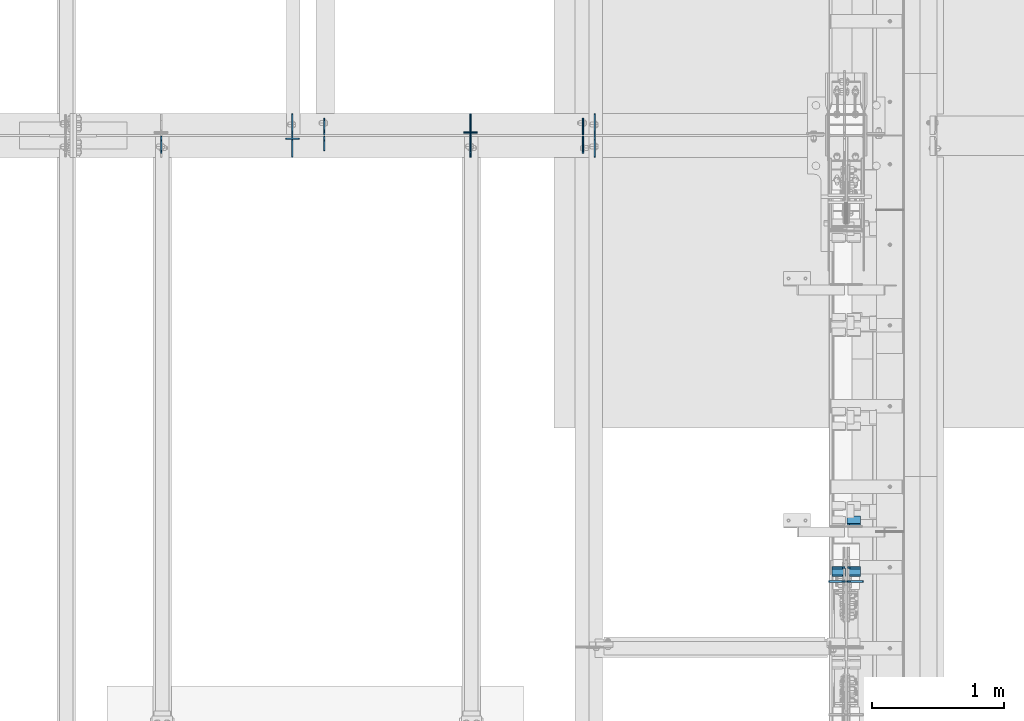
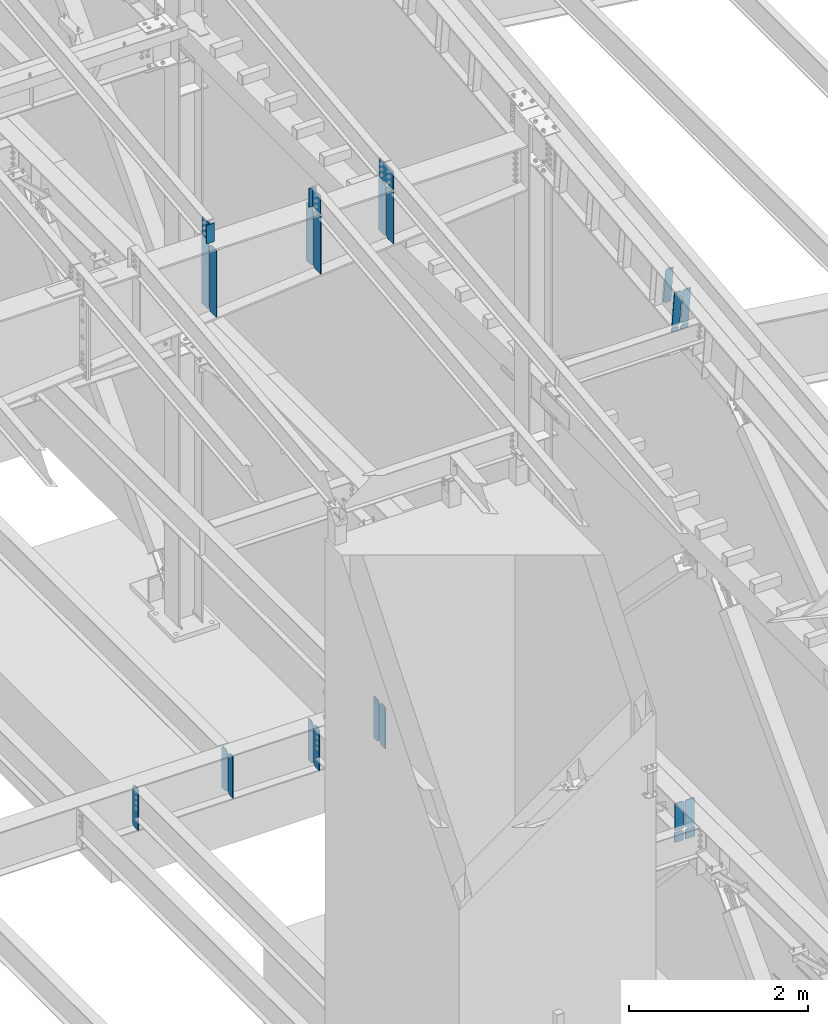
# One storey, part 1032 of 1179: 27 plates, 4 elements without a shape of their own.
"""IFC2X3 building model written with IfcOpenShell, lengths in millimetres."""

from ifc_helpers import new_model, si_unit, frame, origin_with_axes, place, context, subcontext, project, spatial, faceted_brep, material, type_object, element, aggregate, save


model = new_model("IFC2X3")

# Units and contexts
model_context = context("Model", 3, precision=1e-05, world=origin_with_axes())
body_context = subcontext(model_context, "Body", "Model", "MODEL_VIEW")
ifc_project = project(units=[si_unit("LENGTHUNIT", "METRE", prefix="MILLI"), si_unit("AREAUNIT", "SQUARE_METRE"), si_unit("VOLUMEUNIT", "CUBIC_METRE"), si_unit("MASSUNIT", "GRAM", prefix="KILO"), si_unit("TIMEUNIT", "SECOND"), si_unit("PLANEANGLEUNIT", "RADIAN"), si_unit("SOLIDANGLEUNIT", "STERADIAN"), si_unit("THERMODYNAMICTEMPERATUREUNIT", "DEGREE_CELSIUS"), si_unit("LUMINOUSINTENSITYUNIT", "LUMEN")], contexts=[model_context])

# Site, building, storey
site_placement = place(None, origin_with_axes())
site = spatial("IfcSite", under=ifc_project, at=site_placement, CompositionType="ELEMENT")
building_placement = place(site_placement, origin_with_axes())
building = spatial("IfcBuilding", under=site, at=building_placement, Name="Undefined", CompositionType="ELEMENT")
storey_placement = place(building_placement, origin_with_axes())
storey = spatial("IfcBuildingStorey", under=building, at=storey_placement, Name="Undefined", CompositionType="ELEMENT", Elevation=0.0)

# Assembly, plates
assembly_1_placement = place(storey_placement, origin_with_axes())
assembly_1 = element("IfcElementAssembly", 1, at=assembly_1_placement, inside=storey, Name="BEAM", AssemblyPlace="NOTDEFINED", PredefinedType="RIGID_FRAME")
ifc_material_1 = material(Name="STEEL/A36")
plate_type_1 = type_object("IfcPlateType", PredefinedType="NOTDEFINED")
plate_1_placement = place(assembly_1_placement, frame((22318.661882941, 19222.24375, 3514.725), z_axis=(0.0, 0.0, 1.0), x_axis=(0.0, -1.0, 0.0)))
plate_1 = element("IfcPlate", 2, at=plate_1_placement, type_object=plate_type_1, material=ifc_material_1, Name="PLATE", context=body_context, shape_type="Brep", body=[
    faceted_brep([(108.743750000001, -4.76250000000073, 571.5), (108.743750000001, -4.76250000000073, 568.324999809266), (108.743750000001, 4.76250000000073, 568.324999809266), (108.743750000001, 4.76250000000073, 571.5), (109.710479922593, -4.76250000000073, 563.46492029122), (109.710479922593, 4.76250000000073, 563.46492029122), (112.463493823067, -4.76250000000073, 559.344743823066), (112.463493823067, 4.76250000000073, 559.344743823066), (116.58367029122, -4.76250000000073, 556.591729922588), (116.58367029122, 4.76250000000073, 556.591729922588), (121.443749809267, -4.76250000000073, 555.625), (121.443749809267, 4.76250000000073, 555.625), (127.000004116075, -4.76250000000073, 555.625), (127.000004116075, 4.76250000000073, 555.625), (0.0, -4.76250000000073, 536.575000762939), (34.9249992370605, -4.76250000000073, 571.5), (34.9249992370605, 4.76250000000073, 571.5), (0.0, 4.76250000000073, 536.575000762939), (0.0, -4.76250000000073, 34.9249999999993), (0.0, 4.76250000000073, 34.9249999999993), (34.9249992370715, -4.76249999996799, 0.0), (34.9249992370678, 4.76250000003347, 0.0), (127.0, -4.76250000000073, 0.0), (127.0, 4.76250000000073, 0.0)], [[[0, 1, 2, 3]], [[4, 5, 2, 1]], [[6, 7, 5, 4]], [[8, 9, 7, 6]], [[10, 11, 9, 8]], [[12, 13, 11, 10]], [[14, 15, 16, 17]], [[18, 14, 17, 19]], [[20, 18, 19, 21]], [[22, 20, 21, 23]], [[8, 6, 4, 1, 0, 15, 14, 18, 20, 22, 12, 10]], [[16, 15, 0, 3]], [[23, 21, 19, 17, 16, 3, 2, 5, 7, 9, 11, 13]], [[22, 23, 13, 12]]]),
])
plate_2_placement = place(assembly_1_placement, frame((22318.6620000839, 19233.35625, 3514.725), z_axis=(0.0, 0.0, 1.0), x_axis=(0.0, 1.0, 0.0)))
plate_2 = element("IfcPlate", 3, at=plate_2_placement, type_object=plate_type_1, material=ifc_material_1, Name="PLATE", context=body_context, shape_type="Brep", body=[
    faceted_brep([(108.743750000001, -4.76250000000073, 571.5), (108.743750000001, -4.76250000000073, 568.324999809266), (108.743750000001, 4.76250000000073, 568.324999809266), (108.743750000001, 4.76250000000073, 571.5), (109.710479922593, -4.76250000000073, 563.46492029122), (109.710479922593, 4.76250000000073, 563.46492029122), (112.463493823067, -4.76250000000073, 559.344743823066), (112.463493823067, 4.76250000000073, 559.344743823066), (116.58367029122, -4.76250000000073, 556.591729922588), (116.58367029122, 4.76250000000073, 556.591729922588), (121.443749809267, -4.76250000000073, 555.625), (121.443749809267, 4.76250000000073, 555.625), (127.000004116075, -4.76250000000073, 555.625), (127.000004116075, 4.76250000000073, 555.625), (0.0, -4.76250000000073, 536.575000762939), (34.9249992370605, -4.76250000000073, 571.5), (34.9249992370605, 4.76250000000073, 571.5), (0.0, 4.76250000000073, 536.575000762939), (0.0, -4.76250000000073, 34.9249999999993), (0.0, 4.76250000000073, 34.9249999999993), (34.9249992370715, -4.76249999996799, 0.0), (34.9249992370678, 4.76250000003347, 0.0), (127.0, -4.76250000000073, 0.0), (127.0, 4.76250000000073, 0.0)], [[[0, 1, 2, 3]], [[4, 5, 2, 1]], [[6, 7, 5, 4]], [[8, 9, 7, 6]], [[10, 11, 9, 8]], [[12, 13, 11, 10]], [[14, 15, 16, 17]], [[18, 14, 17, 19]], [[20, 18, 19, 21]], [[22, 20, 21, 23]], [[8, 6, 4, 1, 0, 15, 14, 18, 20, 22, 12, 10]], [[16, 15, 0, 3]], [[23, 21, 19, 17, 16, 3, 2, 5, 7, 9, 11, 13]], [[22, 23, 13, 12]]]),
])
plate_3_placement = place(assembly_1_placement, frame((20362.8620000839, 19233.35625, 3514.725), z_axis=(0.0, 0.0, 1.0), x_axis=(0.0, 1.0, 0.0)))
plate_3 = element("IfcPlate", 4, at=plate_3_placement, type_object=plate_type_1, material=ifc_material_1, Name="PLATE", context=body_context, shape_type="Brep", body=[
    faceted_brep([(108.743602752693, -4.76250000000073, 571.5), (108.743602752693, -4.76188288369667, 568.324999809298), (108.743602752693, 4.76250000000073, 568.324999809298), (108.743602752693, 4.76250000000073, 571.5), (109.71033267528, -4.76188288369667, 563.464920291253), (109.71033267528, 4.76250000000073, 563.464920291253), (112.463346575758, -4.76188288369667, 559.344743823099), (112.463346575758, 4.76250000000073, 559.344743823099), (116.583523043912, -4.76188288369667, 556.591729922621), (116.583523043912, 4.76250000000073, 556.591729922621), (121.443602561958, -4.76188288369667, 555.625000000033), (121.443602561958, 4.76250000000073, 555.625000000033), (127.000007629402, -4.76188288369667, 555.625000000033), (127.000004116075, 4.76250000000073, 555.625), (0.0, -4.76250000000073, 536.575000762939), (34.9249992370605, -4.76250000000073, 571.5), (34.9249992370605, 4.76250000000073, 571.5), (0.0, 4.76250000000073, 536.575000762939), (0.0, -4.76250000000073, 34.9249999999993), (0.0, 4.76250000000073, 34.9249999999993), (34.9249992370715, -4.76249999996799, 0.0), (34.9249992370678, 4.76250000003347, 0.0), (127.0, -4.76250000000073, 0.0), (127.0, 4.76250000000073, 0.0)], [[[0, 1, 2, 3]], [[4, 5, 2, 1]], [[6, 7, 5, 4]], [[8, 9, 7, 6]], [[10, 11, 9, 8]], [[12, 13, 11, 10]], [[14, 15, 16, 17]], [[18, 14, 17, 19]], [[20, 18, 19, 21]], [[22, 20, 21, 23]], [[8, 6, 4, 1, 0, 15, 14, 18, 20, 22, 12, 10]], [[16, 15, 0, 3]], [[23, 21, 19, 17, 16, 3, 2, 5, 7, 9, 11, 13]], [[22, 23, 13, 12]]]),
])
plate_4_placement = place(assembly_1_placement, frame((21467.7620000839, 19222.24375, 3514.725), z_axis=(0.0, 0.0, 1.0), x_axis=(0.0, -1.0, 0.0)))
plate_4 = element("IfcPlate", 5, at=plate_4_placement, type_object=plate_type_1, material=ifc_material_1, Name="PLATE", context=body_context, shape_type="Brep", body=[
    faceted_brep([(108.743602752693, -4.76250000000073, 571.5), (108.743602752693, -4.76188288369667, 568.324999809298), (108.743602752693, 4.76250000000073, 568.324999809298), (108.743602752693, 4.76250000000073, 571.5), (109.71033267528, -4.76188288369667, 563.464920291253), (109.71033267528, 4.76250000000073, 563.464920291253), (112.463346575758, -4.76188288369667, 559.344743823099), (112.463346575758, 4.76250000000073, 559.344743823099), (116.583523043912, -4.76188288369667, 556.591729922621), (116.583523043912, 4.76250000000073, 556.591729922621), (121.443602561958, -4.76188288369667, 555.625000000033), (121.443602561958, 4.76250000000073, 555.625000000033), (127.000007629402, -4.76188288369667, 555.625000000033), (127.000004116075, 4.76250000000073, 555.625), (0.0, -4.76250000000073, 536.575000762939), (34.9249992370605, -4.76250000000073, 571.5), (34.9249992370605, 4.76250000000073, 571.5), (0.0, 4.76250000000073, 536.575000762939), (0.0, -4.76250000000073, 34.9249999999993), (0.0, 4.76250000000073, 34.9249999999993), (34.9249992370715, -4.76249999996799, 0.0), (34.9249992370678, 4.76250000003347, 0.0), (127.0, -4.76250000000073, 0.0), (127.0, 4.76250000000073, 0.0)], [[[0, 1, 2, 3]], [[4, 5, 2, 1]], [[6, 7, 5, 4]], [[8, 9, 7, 6]], [[10, 11, 9, 8]], [[12, 13, 11, 10]], [[14, 15, 16, 17]], [[18, 14, 17, 19]], [[20, 18, 19, 21]], [[22, 20, 21, 23]], [[8, 6, 4, 1, 0, 15, 14, 18, 20, 22, 12, 10]], [[16, 15, 0, 3]], [[23, 21, 19, 17, 16, 3, 2, 5, 7, 9, 11, 13]], [[22, 23, 13, 12]]]),
])
plate_5_placement = place(assembly_1_placement, frame((19130.9620000839, 19222.24375, 3514.725), z_axis=(0.0, 0.0, 1.0), x_axis=(0.0, -1.0, 0.0)))
plate_5 = element("IfcPlate", 6, at=plate_5_placement, type_object=plate_type_1, material=ifc_material_1, Name="PLATE", context=body_context, shape_type="Brep", body=[
    faceted_brep([(108.743602752693, -4.76250000000073, 571.5), (108.743602752693, -4.76188288369667, 568.324999809298), (108.743602752693, 4.76250000000073, 568.324999809298), (108.743602752693, 4.76250000000073, 571.5), (109.71033267528, -4.76188288369667, 563.464920291253), (109.71033267528, 4.76250000000073, 563.464920291253), (112.463346575758, -4.76188288369667, 559.344743823099), (112.463346575758, 4.76250000000073, 559.344743823099), (116.583523043912, -4.76188288369667, 556.591729922621), (116.583523043912, 4.76250000000073, 556.591729922621), (121.443602561958, -4.76188288369667, 555.625000000033), (121.443602561958, 4.76250000000073, 555.625000000033), (127.000007629402, -4.76188288369667, 555.625000000033), (127.000004116075, 4.76250000000073, 555.625), (0.0, -4.76250000000073, 536.575000762939), (34.9249992370605, -4.76250000000073, 571.5), (34.9249992370605, 4.76250000000073, 571.5), (0.0, 4.76250000000073, 536.575000762939), (0.0, -4.76250000000073, 34.9249999999993), (0.0, 4.76250000000073, 34.9249999999993), (34.9249992370715, -4.76249999996799, 0.0), (34.9249992370678, 4.76250000003347, 0.0), (127.0, -4.76250000000073, 0.0), (127.0, 4.76250000000073, 0.0)], [[[0, 1, 2, 3]], [[4, 5, 2, 1]], [[6, 7, 5, 4]], [[8, 9, 7, 6]], [[10, 11, 9, 8]], [[12, 13, 11, 10]], [[14, 15, 16, 17]], [[18, 14, 17, 19]], [[20, 18, 19, 21]], [[22, 20, 21, 23]], [[8, 6, 4, 1, 0, 15, 14, 18, 20, 22, 12, 10]], [[16, 15, 0, 3]], [[23, 21, 19, 17, 16, 3, 2, 5, 7, 9, 11, 13]], [[22, 23, 13, 12]]]),
])

assembly_2_placement = place(storey_placement, origin_with_axes())
assembly_2 = element("IfcElementAssembly", 7, at=assembly_2_placement, inside=storey, Name="RAFTER BEAM", AssemblyPlace="NOTDEFINED", PredefinedType="RIGID_FRAME")
plate_type_2 = type_object("IfcPlateType", PredefinedType="NOTDEFINED")
plate_6_placement = place(assembly_2_placement, frame((20121.5625009335, 19392.8999999624, 11103.7687496185), z_axis=(0.0, 0.0, -1.0), x_axis=(0.0, -1.0, 0.0)))
plate_6 = element("IfcPlate", 8, at=plate_6_placement, type_object=plate_type_2, material=ifc_material_1, Name="PLATE", context=body_context, shape_type="Brep", body=[
    faceted_brep([(0.0, -4.76249999999709, 0.0), (-2.08691562875174e-06, -4.76250000000073, 913.722326068595), (-2.08691562875174e-06, 4.76250000000073, 913.722326068595), (0.0, 4.76249999999709, 0.0), (131.762498294553, -4.76250000000073, 913.722326388206), (131.762498294553, 4.76250000000073, 913.722326388206), (157.162497971098, -4.76250000000073, 888.322326831285), (157.162497971098, 4.76250000000073, 888.322326831285), (157.162499942613, -4.76250000000073, 25.3999996182793), (157.162499942613, 4.76250000000073, 25.3999996182793), (131.762500381465, -4.76250000000073, -2.09183781407773e-10), (131.762500381465, 4.76250000000073, -2.09183781407773e-10)], [[[0, 1, 2, 3]], [[1, 4, 5, 2]], [[4, 6, 7, 5]], [[6, 8, 9, 7]], [[8, 10, 11, 9]], [[10, 0, 3, 11]], [[5, 7, 9, 11, 3, 2]], [[10, 8, 6, 4, 1, 0]]]),
])
plate_7_placement = place(assembly_2_placement, frame((21467.7625, 19392.8999999624, 11103.7687496185), z_axis=(0.0, 0.0, -1.0), x_axis=(0.0, -1.0, 0.0)))
plate_7 = element("IfcPlate", 9, at=plate_7_placement, type_object=plate_type_2, material=ifc_material_1, Name="PLATE", context=body_context, shape_type="Brep", body=[
    faceted_brep([(0.0, -4.76249999999709, 0.0), (-1.85116005013697e-06, -4.76250000000073, 795.843735329721), (-1.85116005013697e-06, 4.76250000000073, 795.843735329721), (0.0, 4.76249999999709, 0.0), (131.762498530312, -4.76250000000073, 795.843735649332), (131.762498530312, 4.76250000000073, 795.843735649332), (157.162498207919, -4.76250000000073, 770.443736092411), (157.162498207919, 4.76250000000073, 770.443736092411), (157.162499942613, -4.76250000000073, 25.3999996182793), (157.162499942613, 4.76250000000073, 25.3999996182793), (131.762500381465, -4.76250000000073, -2.09183781407773e-10), (131.762500381465, 4.76250000000073, -2.09183781407773e-10)], [[[0, 1, 2, 3]], [[1, 4, 5, 2]], [[4, 6, 7, 5]], [[6, 8, 9, 7]], [[8, 10, 11, 9]], [[10, 0, 3, 11]], [[5, 7, 9, 11, 3, 2]], [[10, 8, 6, 4, 1, 0]]]),
])
plate_8_placement = place(assembly_2_placement, frame((22407.5625, 19392.8999999624, 11103.7687496185), z_axis=(0.0, 0.0, -1.0), x_axis=(0.0, -1.0, 0.0)))
plate_8 = element("IfcPlate", 10, at=plate_8_placement, type_object=plate_type_2, material=ifc_material_1, Name="PLATE", context=body_context, shape_type="Brep", body=[
    faceted_brep([(0.0, -4.76249999999709, 0.0), (-1.68650149134919e-06, -4.76250000000073, 713.502596248929), (-1.68650149134919e-06, 4.76250000000073, 713.502596248929), (0.0, 4.76249999999709, 0.0), (131.762498694967, -4.76250000000073, 713.50259656854), (131.762498694967, 4.76250000000073, 713.50259656854), (157.162498373538, -4.76250000000073, 688.102597011619), (157.162498373538, 4.76250000000073, 688.102597011619), (157.162499942613, -4.76250000000073, 25.3999996182793), (157.162499942613, 4.76250000000073, 25.3999996182793), (131.762500381465, -4.76250000000073, -2.09183781407773e-10), (131.762500381465, 4.76250000000073, -2.09183781407773e-10)], [[[0, 1, 2, 3]], [[1, 4, 5, 2]], [[4, 6, 7, 5]], [[6, 8, 9, 7]], [[8, 10, 11, 9]], [[10, 0, 3, 11]], [[5, 7, 9, 11, 3, 2]], [[10, 8, 6, 4, 1, 0]]]),
])
plate_9_placement = place(assembly_2_placement, frame((20121.5625009335, 19062.6999999987, 11103.7687496185), z_axis=(0.0, 0.0, -1.0), x_axis=(0.0, 1.0, 0.0)))
plate_9 = element("IfcPlate", 11, at=plate_9_placement, type_object=plate_type_2, material=ifc_material_1, Name="PLATE", context=body_context, shape_type="Brep", body=[
    faceted_brep([(0.0, -4.76249999999709, 0.0), (-2.08691562875174e-06, -4.76250000000073, 913.722326068595), (-2.08691562875174e-06, 4.76250000000073, 913.722326068595), (0.0, 4.76249999999709, 0.0), (131.762498294553, -4.76250000000073, 913.722326388206), (131.762498294553, 4.76250000000073, 913.722326388206), (157.162497971098, -4.76250000000073, 888.322326831285), (157.162497971098, 4.76250000000073, 888.322326831285), (157.162499942613, -4.76250000000073, 25.3999996182793), (157.162499942613, 4.76250000000073, 25.3999996182793), (131.762500381465, -4.76250000000073, -2.09183781407773e-10), (131.762500381465, 4.76250000000073, -2.09183781407773e-10)], [[[0, 1, 2, 3]], [[1, 4, 5, 2]], [[4, 6, 7, 5]], [[6, 8, 9, 7]], [[8, 10, 11, 9]], [[10, 0, 3, 11]], [[5, 7, 9, 11, 3, 2]], [[10, 8, 6, 4, 1, 0]]]),
])
plate_10_placement = place(assembly_2_placement, frame((21467.7625, 19062.6999999987, 11103.7687496185), z_axis=(0.0, 0.0, -1.0), x_axis=(0.0, 1.0, 0.0)))
plate_10 = element("IfcPlate", 12, at=plate_10_placement, type_object=plate_type_2, material=ifc_material_1, Name="PLATE", context=body_context, shape_type="Brep", body=[
    faceted_brep([(0.0, -4.76249999999709, 0.0), (-1.85116005013697e-06, -4.76250000000073, 795.843735329721), (-1.85116005013697e-06, 4.76250000000073, 795.843735329721), (0.0, 4.76249999999709, 0.0), (131.762498530312, -4.76250000000073, 795.843735649332), (131.762498530312, 4.76250000000073, 795.843735649332), (157.162498207919, -4.76250000000073, 770.443736092411), (157.162498207919, 4.76250000000073, 770.443736092411), (157.162499942613, -4.76250000000073, 25.3999996182793), (157.162499942613, 4.76250000000073, 25.3999996182793), (131.762500381465, -4.76250000000073, -2.09183781407773e-10), (131.762500381465, 4.76250000000073, -2.09183781407773e-10)], [[[0, 1, 2, 3]], [[1, 4, 5, 2]], [[4, 6, 7, 5]], [[6, 8, 9, 7]], [[8, 10, 11, 9]], [[10, 0, 3, 11]], [[5, 7, 9, 11, 3, 2]], [[10, 8, 6, 4, 1, 0]]]),
])
plate_11_placement = place(assembly_2_placement, frame((22407.5625, 19062.6999999987, 11103.7687496185), z_axis=(0.0, 0.0, -1.0), x_axis=(0.0, 1.0, 0.0)))
plate_11 = element("IfcPlate", 13, at=plate_11_placement, type_object=plate_type_2, material=ifc_material_1, Name="PLATE", context=body_context, shape_type="Brep", body=[
    faceted_brep([(0.0, -4.76249999999709, 0.0), (-1.68650149134919e-06, -4.76250000000073, 713.502596248929), (-1.68650149134919e-06, 4.76250000000073, 713.502596248929), (0.0, 4.76249999999709, 0.0), (131.762498694967, -4.76250000000073, 713.50259656854), (131.762498694967, 4.76250000000073, 713.50259656854), (157.162498373538, -4.76250000000073, 688.102597011619), (157.162498373538, 4.76250000000073, 688.102597011619), (157.162499942613, -4.76250000000073, 25.3999996182793), (157.162499942613, 4.76250000000073, 25.3999996182793), (131.762500381465, -4.76250000000073, -2.09183781407773e-10), (131.762500381465, 4.76250000000073, -2.09183781407773e-10)], [[[0, 1, 2, 3]], [[1, 4, 5, 2]], [[4, 6, 7, 5]], [[6, 8, 9, 7]], [[8, 10, 11, 9]], [[10, 0, 3, 11]], [[5, 7, 9, 11, 3, 2]], [[10, 8, 6, 4, 1, 0]]]),
])

assembly_3_placement = place(storey_placement, origin_with_axes())
assembly_3 = element("IfcElementAssembly", 14, at=assembly_3_placement, inside=storey, Name="BEAM", AssemblyPlace="NOTDEFINED", PredefinedType="RIGID_FRAME")
ifc_material_2 = material(Name="STEEL/A572-GR.50")
plate_type_3 = type_object("IfcPlateType", PredefinedType="NOTDEFINED")
plate_12_placement = place(assembly_3_placement, frame((24414.1625, 15956.4822255243, 10522.7324669525), z_axis=(0.0, -0.112284087038017, 0.993676146336441), x_axis=(-1.0, 0.0, 0.0)))
plate_12 = element("IfcPlate", 15, at=plate_12_placement, type_object=plate_type_3, material=ifc_material_2, Name="PLATE", context=body_context, shape_type="Brep", body=[
    faceted_brep([(0.0, -6.34999999999854, 0.0), (0.0, -6.35000000019863, 498.474999998592), (0.0, 6.34999999979118, 498.474999998596), (0.0, 6.34999999999854, 0.0), (80.1687507629395, -6.35000000020227, 498.474999998592), (80.1687507629395, 6.34999999978754, 498.474999998596), (99.21875, -6.350000000195, 479.425000761543), (99.21875, 6.34999999980209, 479.425000761548), (99.21875, -6.35000000000946, 19.0499992370478), (99.21875, 6.34999999998399, 19.0499992370533), (80.1687507629395, -6.35000000000218, 0.0), (80.1687507629395, 6.34999999999491, 3.63797880709171e-12)], [[[0, 1, 2, 3]], [[1, 4, 5, 2]], [[4, 6, 7, 5]], [[6, 8, 9, 7]], [[8, 10, 11, 9]], [[10, 0, 3, 11]], [[5, 7, 9, 11, 3, 2]], [[10, 8, 6, 4, 1, 0]]]),
])
plate_13_placement = place(assembly_3_placement, frame((24300.65625, 15956.4822255243, 10522.7324669525), z_axis=(0.0, -0.112284087038017, 0.993676146336441), x_axis=(-1.0, 0.0, 0.0)))
plate_13 = element("IfcPlate", 16, at=plate_13_placement, type_object=plate_type_3, material=ifc_material_2, Name="PLATE", context=body_context, shape_type="Brep", body=[
    faceted_brep([(0.0, -6.35000000000036, 19.0499999999993), (0.0, -6.350000000195, 479.425000761541), (0.0, 6.34999999980209, 479.425000761548), (0.0, 6.35000000000036, 19.0499999999993), (19.0499992370605, -6.35000000019863, 498.474999998592), (19.0499992370605, 6.34999999979118, 498.474999998596), (99.21875, -6.35000000020227, 498.474999998592), (99.21875, 6.34999999978754, 498.474999998596), (99.21875, -6.35000000000218, 0.0), (99.21875, 6.34999999999491, 3.63797880709171e-12), (19.0500000000002, -6.35000000000036, 0.0), (19.0500000000002, 6.35000000000036, 0.0)], [[[0, 1, 2, 3]], [[1, 4, 5, 2]], [[4, 6, 7, 5]], [[6, 8, 9, 7]], [[8, 10, 11, 9]], [[3, 11, 10, 0]], [[5, 7, 9, 11, 3, 2]], [[10, 8, 6, 4, 1, 0]]]),
])

assembly_4_placement = place(storey_placement, origin_with_axes())
assembly_4 = element("IfcElementAssembly", 17, at=assembly_4_placement, inside=storey, Name="BEAM", AssemblyPlace="NOTDEFINED", PredefinedType="RIGID_FRAME")
plate_type_4 = type_object("IfcPlateType", PredefinedType="NOTDEFINED")
plate_14_placement = place(assembly_4_placement, frame((24434.00625, 15857.8351561904, 3703.6375), z_axis=(0.0, 0.0, 1.0), x_axis=(-1.0, 0.0, 0.0)))
plate_14 = element("IfcPlate", 18, at=plate_14_placement, type_object=plate_type_4, material=ifc_material_2, Name="PLATE", context=body_context, shape_type="Brep", body=[
    faceted_brep([(0.0, -6.34999999999854, 0.0), (0.0, -6.35000000000036, 377.825012207031), (0.0, 6.35000000000036, 377.825012207031), (0.0, 6.34999999999854, 0.0), (98.4250011444092, -6.35000000000036, 377.825012207031), (98.4250011444092, 6.35000000000036, 377.825012207031), (120.650001525879, -6.35000000000036, 355.600011825562), (120.650001525879, 6.35000000000036, 355.600011825562), (120.650001525879, -6.35000000000036, 22.2250003814697), (120.650001525879, 6.35000000000036, 22.2250003814697), (98.4250011444092, -6.35000000000036, 0.0), (98.4250011444092, 6.35000000000036, 0.0)], [[[0, 1, 2, 3]], [[1, 4, 5, 2]], [[4, 6, 7, 5]], [[6, 8, 9, 7]], [[8, 10, 11, 9]], [[10, 0, 3, 11]], [[5, 7, 9, 11, 3, 2]], [[10, 8, 6, 4, 1, 0]]]),
])
plate_15_placement = place(assembly_4_placement, frame((24302.24375, 15857.8351561904, 3703.6375), z_axis=(0.0, 0.0, 1.0), x_axis=(-1.0, 0.0, 0.0)))
plate_15 = element("IfcPlate", 19, at=plate_15_placement, type_object=plate_type_4, material=ifc_material_2, Name="PLATE", context=body_context, shape_type="Brep", body=[
    faceted_brep([(0.0, -6.34999999999854, 22.2250003814697), (0.0, -6.34999999999854, 355.600011825562), (0.0, 6.34999999999854, 355.600011825562), (0.0, 6.34999999999854, 22.2250003814697), (22.2250003814697, -6.34999999999854, 377.825012207031), (22.2250003814697, 6.34999999999854, 377.825012207031), (120.650001525879, -6.34999999999854, 377.825012207031), (120.650001525879, 6.34999999999854, 377.825012207031), (120.650001525879, -6.34999999999854, 0.0), (120.650001525879, 6.34999999999854, 0.0), (22.2250003814697, -6.34999999999854, 0.0), (22.2250003814697, 6.34999999999854, 0.0)], [[[0, 1, 2, 3]], [[1, 4, 5, 2]], [[4, 6, 7, 5]], [[6, 8, 9, 7]], [[8, 10, 11, 9]], [[10, 0, 3, 11]], [[5, 7, 9, 11, 3, 2]], [[10, 8, 6, 4, 1, 0]]]),
])

# Plate
plate_type_5 = type_object("IfcPlateType", PredefinedType="NOTDEFINED")
plate_16_placement = place(assembly_3_placement, frame((24298.275, 15959.3342412636, 10497.4930934683), z_axis=(-1.0, 0.0, 0.0), x_axis=(0.0, 0.112284087038014, -0.993676146336441)))
plate_16 = element("IfcPlate", 20, at=plate_16_placement, type_object=plate_type_5, material=ifc_material_2, Name="CB", context=body_context, shape_type="Brep", body=[
    faceted_brep([(0.0, 6.35000000000036, 19.0499999999993), (19.0500000000002, 6.35000000000036, 0.0), (19.0500000000002, -6.35000000000036, 0.0), (0.0, -6.35000000000036, 19.0499999999993), (0.0, -6.35000000000036, 96.8374999999978), (0.0, 6.35000000000036, 96.8374999999978), (56.6681223496835, -6.34999999997308, 96.8374999999978), (56.6681223496798, 6.35000000002037, 96.8374999999978), (56.6681223496835, -6.34999999997308, 0.0), (56.6681223496798, 6.35000000002037, 0.0)], [[[0, 1, 2, 3]], [[4, 5, 0, 3]], [[4, 6, 7, 5]], [[6, 8, 9, 7]], [[9, 8, 2, 1]], [[5, 7, 9, 1, 0]], [[8, 6, 4, 3, 2]]]),
])

plate_17_placement = place(assembly_3_placement, frame((24317.325, 15959.3342412636, 10497.4930934683), z_axis=(1.0, 0.0, 0.0), x_axis=(0.0, 0.112284087038014, -0.993676146336441)))
plate_17 = element("IfcPlate", 21, at=plate_17_placement, type_object=plate_type_5, material=ifc_material_2, Name="CB", context=body_context, shape_type="Brep", body=[
    faceted_brep([(0.0, 6.35000000000036, 19.0499999999993), (19.0500000000002, 6.35000000000036, 0.0), (19.0500000000002, -6.35000000000036, 0.0), (0.0, -6.35000000000036, 19.0499999999993), (0.0, -6.35000000000036, 96.8374999999978), (0.0, 6.35000000000036, 96.8374999999978), (56.6681223496835, -6.34999999997308, 96.8374999999978), (56.6681223496798, 6.35000000002037, 96.8374999999978), (56.6681223496835, -6.34999999997308, 0.0), (56.6681223496798, 6.35000000002037, 0.0)], [[[0, 1, 2, 3]], [[4, 5, 0, 3]], [[4, 6, 7, 5]], [[6, 8, 9, 7]], [[9, 8, 2, 1]], [[5, 7, 9, 1, 0]], [[8, 6, 4, 3, 2]]]),
])

plate_type_6 = type_object("IfcPlateType", PredefinedType="NOTDEFINED")
plate_18_placement = place(assembly_2_placement, frame((20121.5625, 19386.5500001466, 11127.5812496554), z_axis=(0.0, -1.0, 0.0), x_axis=(0.0, 0.0, 1.0)))
plate_18 = element("IfcPlate", 22, at=plate_18_placement, type_object=plate_type_6, material=ifc_material_1, Name="PLATE", context=body_context, shape_type="Brep", body=[
    faceted_brep([(0.0, -4.76249999999709, 0.0), (3.08111339109018e-07, -4.76250000000073, 177.800000293439), (3.08111339109018e-07, 4.76250000000073, 177.800000293439), (0.0, 4.76249999999709, 0.0), (254.0, -4.76250000000073, 177.799999999999), (254.0, 4.76250000000073, 177.799999999999), (254.0, -4.76250000000073, 0.0), (254.0, 4.76250000000073, 0.0)], [[[0, 1, 2, 3]], [[1, 4, 5, 2]], [[4, 6, 7, 5]], [[6, 0, 3, 7]], [[5, 7, 3, 2]], [[6, 4, 1, 0]]]),
])

plate_19_placement = place(assembly_2_placement, frame((21467.7625, 19246.8500001379, 11127.5812496544), z_axis=(0.0, -1.0, 0.0), x_axis=(0.0, 0.0, 1.0)))
plate_19 = element("IfcPlate", 23, at=plate_19_placement, type_object=plate_type_6, material=ifc_material_1, Name="PLATE", context=body_context, shape_type="Brep", body=[
    faceted_brep([(0.0, -4.76249999999709, 0.0), (3.08111339109018e-07, -4.76250000000073, 177.800000293439), (3.08111339109018e-07, 4.76250000000073, 177.800000293439), (0.0, 4.76249999999709, 0.0), (254.0, -4.76250000000073, 177.799999999999), (254.0, 4.76250000000073, 177.799999999999), (254.0, -4.76250000000073, 0.0), (254.0, 4.76250000000073, 0.0)], [[[0, 1, 2, 3]], [[1, 4, 5, 2]], [[4, 6, 7, 5]], [[6, 0, 3, 7]], [[5, 7, 3, 2]], [[6, 4, 1, 0]]]),
])

plate_type_7 = type_object("IfcPlateType", PredefinedType="NOTDEFINED")
plate_20_placement = place(assembly_4_placement, frame((24295.1, 15857.7897419099, 3549.97993843474), z_axis=(-1.0, 0.0, 0.0), x_axis=(0.0, 0.0, 1.0)))
plate_20 = element("IfcPlate", 24, at=plate_20_placement, type_object=plate_type_7, material=ifc_material_2, Name="PLATE", context=body_context, shape_type="Brep", body=[
    faceted_brep([(0.0, -6.34999999999854, 0.0), (0.0, -6.35000000000036, 117.474999999999), (0.0, 6.35000000000036, 117.474999999999), (0.0, 6.34999999999854, 0.0), (133.020061565272, -6.35000000000036, 117.474999999999), (133.020061565272, 6.35000000000036, 117.474999999999), (133.020061565272, -6.35000000000036, 19.0499992370605), (133.020061565272, 6.35000000000036, 19.0499992370605), (113.970062328212, -6.35000000000036, 0.0), (113.970062328212, 6.35000000000036, 0.0)], [[[0, 1, 2, 3]], [[1, 4, 5, 2]], [[4, 6, 7, 5]], [[6, 8, 9, 7]], [[8, 0, 3, 9]], [[5, 7, 9, 3, 2]], [[8, 6, 4, 1, 0]]]),
])

plate_21_placement = place(assembly_4_placement, frame((24320.5, 15857.7897419099, 3549.97993843474), z_axis=(1.0, 0.0, 0.0), x_axis=(0.0, 0.0, 1.0)))
plate_21 = element("IfcPlate", 25, at=plate_21_placement, type_object=plate_type_7, material=ifc_material_2, Name="PLATE", context=body_context, shape_type="Brep", body=[
    faceted_brep([(0.0, -6.34999999999854, 0.0), (0.0, -6.35000000000036, 117.474999999999), (0.0, 6.35000000000036, 117.474999999999), (0.0, 6.34999999999854, 0.0), (133.020061565272, -6.35000000000036, 117.474999999999), (133.020061565272, 6.35000000000036, 117.474999999999), (133.020061565272, -6.35000000000036, 19.0499992370605), (133.020061565272, 6.35000000000036, 19.0499992370605), (113.970062328212, -6.35000000000036, 0.0), (113.970062328212, 6.35000000000036, 0.0)], [[[0, 1, 2, 3]], [[1, 4, 5, 2]], [[4, 6, 7, 5]], [[6, 8, 9, 7]], [[8, 0, 3, 9]], [[5, 7, 9, 3, 2]], [[8, 6, 4, 1, 0]]]),
])

aggregate(assembly_4, [plate_14, plate_15, plate_20, plate_21])

plate_type_8 = type_object("IfcPlateType", PredefinedType="NOTDEFINED")
plate_22_placement = place(assembly_3_placement, frame((24414.1625, 16346.2342144593, 10566.7739249366), z_axis=(0.0, -0.112284087038017, 0.993676146336441), x_axis=(-1.0, 0.0, 0.0)))
plate_22 = element("IfcPlate", 26, at=plate_22_placement, type_object=plate_type_8, material=ifc_material_1, Name="PLATE", context=body_context, shape_type="Brep", body=[
    faceted_brep([(0.0, -4.76249999999709, 0.0), (0.0, -4.76250000020082, 498.474999998594), (0.0, 4.76249999979336, 498.474999998596), (0.0, 4.76249999999709, 0.0), (81.7562503814697, -4.76250000020082, 498.474999998594), (81.7562503814697, 4.76249999979336, 498.474999998596), (99.21875, -4.76250000019354, 481.012500380073), (99.21875, 4.76249999980064, 481.012500380079), (99.21875, -4.76250000000437, 17.4624996185212), (99.21875, 4.76249999998981, 17.4624996185248), (81.7562503814697, -4.76250000000073, 0.0), (81.7562503814697, 4.76249999999709, 3.63797880709171e-12)], [[[0, 1, 2, 3]], [[1, 4, 5, 2]], [[4, 6, 7, 5]], [[6, 8, 9, 7]], [[8, 10, 11, 9]], [[10, 0, 3, 11]], [[5, 7, 9, 11, 3, 2]], [[10, 8, 6, 4, 1, 0]]]),
])

aggregate(assembly_3, [plate_12, plate_13, plate_16, plate_17, plate_22])

plate_type_9 = type_object("IfcPlateType", PredefinedType="NOTDEFINED")
plate_23_placement = place(assembly_2_placement, frame((20070.7624995332, 19203.9875046864, 11381.5812496602), z_axis=(0.0, 0.0, -1.0), x_axis=(1.0, 0.0, 0.0)))
plate_23 = element("IfcPlate", 27, at=plate_23_placement, type_object=plate_type_9, material=ifc_material_1, Name="PLATE", context=body_context, shape_type="Brep", body=[
    faceted_brep([(0.0, -4.76249999999709, 0.0), (-3.63797880709171e-12, -4.76249999988795, 253.999999691892), (0.0, 4.7625000001135, 253.99999969189), (0.0, 4.76249999999709, 0.0), (101.600000000017, -4.76249999989886, 254.00000000006), (101.600000000017, 4.76250000010259, 254.000000000058), (101.600000000017, -4.76250000001164, 6.00266503170133e-11), (101.600000000017, 4.76249999998981, 5.82076609134674e-11)], [[[0, 1, 2, 3]], [[1, 4, 5, 2]], [[4, 6, 7, 5]], [[6, 0, 3, 7]], [[5, 7, 3, 2]], [[6, 4, 1, 0]]]),
])

plate_24_placement = place(assembly_2_placement, frame((21416.9625004667, 19251.6125051163, 11381.5812496496), z_axis=(0.0, 0.0, -1.0), x_axis=(1.0, 0.0, 0.0)))
plate_24 = element("IfcPlate", 28, at=plate_24_placement, type_object=plate_type_9, material=ifc_material_1, Name="PLATE", context=body_context, shape_type="Brep", body=[
    faceted_brep([(0.0, -4.76249999999709, 0.0), (-3.63797880709171e-12, -4.76249999988795, 253.999999691892), (0.0, 4.7625000001135, 253.99999969189), (0.0, 4.76249999999709, 0.0), (101.600000000017, -4.76249999989886, 254.00000000006), (101.600000000017, 4.76250000010259, 254.000000000058), (101.600000000017, -4.76250000001164, 6.00266503170133e-11), (101.600000000017, 4.76249999998981, 5.82076609134674e-11)], [[[0, 1, 2, 3]], [[1, 4, 5, 2]], [[4, 6, 7, 5]], [[6, 0, 3, 7]], [[5, 7, 3, 2]], [[6, 4, 1, 0]]]),
])

plate_type_10 = type_object("IfcPlateType", PredefinedType="NOTDEFINED")
plate_25_placement = place(assembly_2_placement, frame((22407.5625, 19386.5500001467, 11127.5812496552), z_axis=(0.0, -1.0, 0.0), x_axis=(0.0, 0.0, 1.0)))
plate_25 = element("IfcPlate", 29, at=plate_25_placement, type_object=plate_type_10, material=ifc_material_1, Name="PLATE", context=body_context, shape_type="Brep", body=[
    faceted_brep([(0.0, -4.76249999999709, 0.0), (8.00355337560177e-11, -4.7624999999889, 317.49999188591), (6.91215973347425e-11, 4.76250000001255, 317.49999188591), (0.0, 4.76249999999709, 0.0), (254.0, -4.76249999999982, 317.5), (254.0, 4.76249999999982, 317.5), (254.0, -4.76250000000073, 0.0), (254.0, 4.76250000000073, 0.0)], [[[0, 1, 2, 3]], [[1, 4, 5, 2]], [[4, 6, 7, 5]], [[6, 0, 3, 7]], [[5, 7, 3, 2]], [[6, 4, 1, 0]]]),
])

aggregate(assembly_2, [plate_6, plate_7, plate_8, plate_9, plate_10, plate_11, plate_23, plate_18, plate_24, plate_19, plate_25])

plate_type_11 = type_object("IfcPlateType", PredefinedType="NOTDEFINED")
plate_26_placement = place(assembly_1_placement, frame((20362.8620000839, 19222.24375, 3514.725), z_axis=(0.0, 0.0, 1.0), x_axis=(0.0, -1.0, 0.0)))
plate_26 = element("IfcPlate", 30, at=plate_26_placement, type_object=plate_type_11, material=ifc_material_1, Name="PLATE", context=body_context, shape_type="Brep", body=[
    faceted_brep([(0.0, -4.76250000000073, 34.9249999999993), (0.0, -4.76250000000073, 536.575000762939), (0.0, 4.76250000000073, 536.575000762939), (0.0, 4.76250000000073, 34.9249999999993), (34.9249992370605, -4.76250000000073, 571.5), (34.9249992370605, 4.76250000000073, 571.5), (107.949996948242, -4.76250000000073, 571.5), (107.949996948242, 4.76250000000073, 571.5), (107.949996948242, -4.76250000000073, 0.0), (107.949996948242, 4.76250000000073, 0.0), (34.9249992370715, -4.76249999996799, 0.0), (34.9249992370678, 4.76250000003347, 0.0)], [[[0, 1, 2, 3]], [[1, 4, 5, 2]], [[4, 6, 7, 5]], [[6, 8, 9, 7]], [[8, 10, 11, 9]], [[10, 0, 3, 11]], [[5, 7, 9, 11, 3, 2]], [[10, 8, 6, 4, 1, 0]]]),
])

plate_27_placement = place(assembly_1_placement, frame((21467.7620000839, 19233.35625, 3514.725), z_axis=(0.0, 0.0, 1.0), x_axis=(0.0, 1.0, 0.0)))
plate_27 = element("IfcPlate", 31, at=plate_27_placement, type_object=plate_type_11, material=ifc_material_1, Name="PLATE", context=body_context, shape_type="Brep", body=[
    faceted_brep([(0.0, -4.76250000000073, 34.9249999999993), (0.0, -4.76250000000073, 536.575000762939), (0.0, 4.76250000000073, 536.575000762939), (0.0, 4.76250000000073, 34.9249999999993), (34.9249992370605, -4.76250000000073, 571.5), (34.9249992370605, 4.76250000000073, 571.5), (107.949996948242, -4.76250000000073, 571.5), (107.949996948242, 4.76250000000073, 571.5), (107.949996948242, -4.76250000000073, 0.0), (107.949996948242, 4.76250000000073, 0.0), (34.9249992370715, -4.76249999996799, 0.0), (34.9249992370678, 4.76250000003347, 0.0)], [[[0, 1, 2, 3]], [[1, 4, 5, 2]], [[4, 6, 7, 5]], [[6, 8, 9, 7]], [[8, 10, 11, 9]], [[10, 0, 3, 11]], [[5, 7, 9, 11, 3, 2]], [[10, 8, 6, 4, 1, 0]]]),
])

aggregate(assembly_1, [plate_1, plate_2, plate_26, plate_3, plate_27, plate_4, plate_5])

save(model, "model.ifc")
